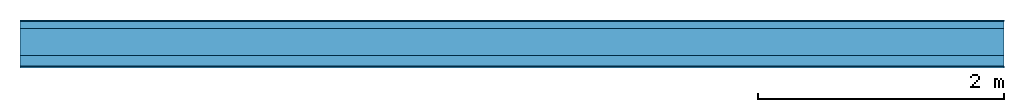
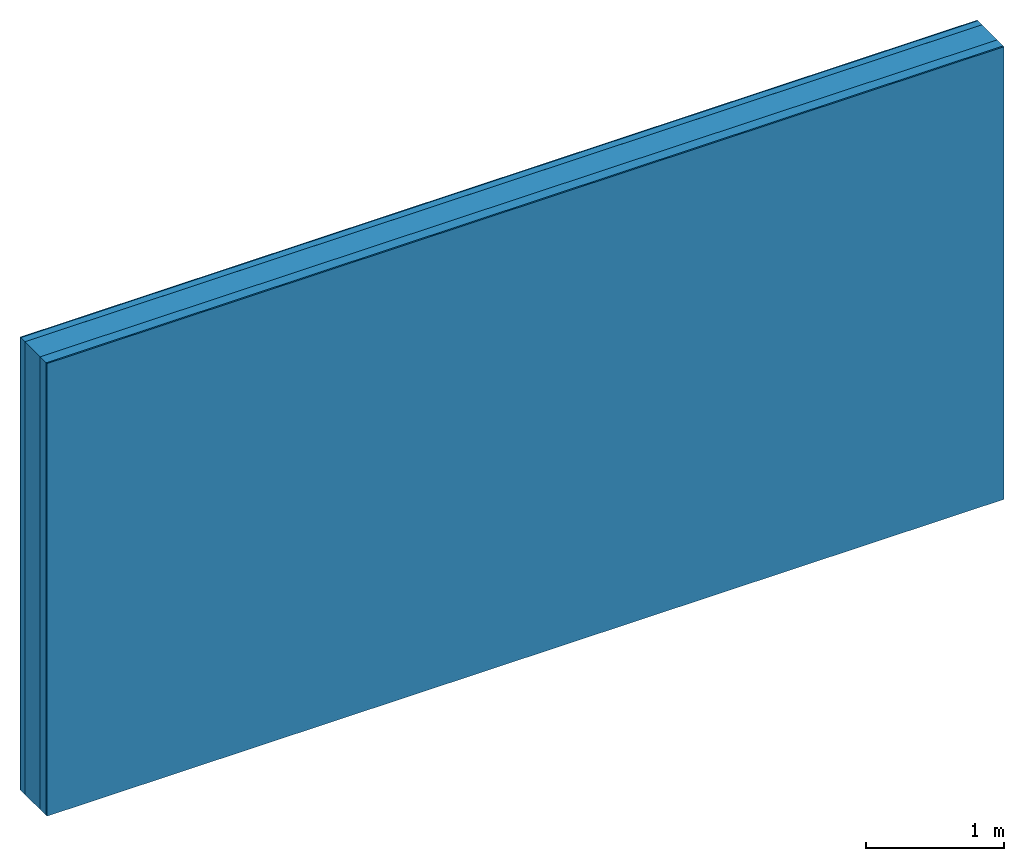
# One storey: 4 plates, 1 member, 1 element without a shape of its own.
"""IFC4 building model written with IfcOpenShell, lengths in metres."""

import ifcopenshell
import ifcopenshell.guid

model = None  # the IFC model being written
_history = None  # IfcOwnerHistory: only IFC2X3 demands one
_inside = {}  # id of a spatial element -> (the spatial element, [elements in it])
_under = {}  # id of a project, library or spatial element -> (it, [spatial elements below it])
_declared = {}  # id of a project -> (the project, [libraries it declares])
_typed = {}  # id of a type object -> (the type object, [elements of that type])
_made_of = {}  # id of a material, layer set ... -> (it, [elements and type objects made of it])


def new_model(schema):
    """Start an empty IFC model of exactly this schema.

    Asked for "IFC4X3", IfcOpenShell would pick the latest addendum, in which some entities
    have other attributes; the version numbers below select the first issue.
    IFC2X3 requires an IfcOwnerHistory on every rooted entity: one is made here for all.
    """
    global model, _history
    if schema == "IFC4X3":
        model = ifcopenshell.file(schema_version=(4, 3, 0, 0))
    else:
        model = ifcopenshell.file(schema=schema)
    _inside.clear()
    _under.clear()
    _declared.clear()
    _typed.clear()
    _made_of.clear()
    _history = None
    if model.schema == "IFC2X3":
        org = make("IfcOrganization", Name="unknown")
        user = make(
            "IfcPersonAndOrganization",
            ThePerson=make("IfcPerson", FamilyName="unknown"),
            TheOrganization=org,
        )
        app = make(
            "IfcApplication",
            ApplicationDeveloper=org,
            Version="unknown",
            ApplicationFullName="unknown",
            ApplicationIdentifier="unknown",
        )
        _history = make(
            "IfcOwnerHistory",
            OwningUser=user,
            OwningApplication=app,
            ChangeAction="ADDED",
            CreationDate=0,
        )
    return model


def make(cls, **values):
    """One entity of the class cls with the attributes given. An attribute that is None is left unset."""
    return model.create_entity(
        cls, **{name: value for name, value in values.items() if value is not None}
    )


def rooted(cls, **values):
    """An entity with a GlobalId (a new one), such as an element, a storey or a relation."""
    return make(cls, GlobalId=ifcopenshell.guid.new(), OwnerHistory=_history, **values)


def si_unit(unit_type, name, prefix=None):
    """IfcSIUnit, for example si_unit("LENGTHUNIT", "METRE", prefix="MILLI")."""
    return make("IfcSIUnit", UnitType=unit_type, Prefix=prefix, Name=name)


def derived_unit(unit_type, elements):
    """IfcDerivedUnit: a product of units, each with its exponent."""
    return make(
        "IfcDerivedUnit",
        Elements=[
            make("IfcDerivedUnitElement", Unit=unit, Exponent=power)
            for unit, power in elements
        ],
        UnitType=unit_type,
    )


def assignment(units):
    """IfcUnitAssignment: the units of a project."""
    return None if units is None else make("IfcUnitAssignment", Units=units)


def point(xyz):
    """IfcCartesianPoint."""
    return None if xyz is None else make("IfcCartesianPoint", Coordinates=xyz)


def direction(xyz):
    """IfcDirection."""
    return None if xyz is None else make("IfcDirection", DirectionRatios=xyz)


def frame(location, z_axis=None, x_axis=None):
    """IfcAxis2Placement3D, a coordinate frame: its origin and axes. An axis left out is left unset."""
    return make(
        "IfcAxis2Placement3D",
        Location=point(location),
        Axis=direction(z_axis),
        RefDirection=direction(x_axis),
    )


def frame_2d(location, x_axis=None):
    """IfcAxis2Placement2D, a coordinate frame in the plane: its origin and x axis."""
    return make(
        "IfcAxis2Placement2D", Location=point(location), RefDirection=direction(x_axis)
    )


def origin():
    """The frame at (0, 0, 0) with its axes left unset."""
    return frame((0.0, 0.0, 0.0))


def origin_with_axes():
    """The frame at (0, 0, 0) with the z axis (0, 0, 1) and the x axis (1, 0, 0) written out."""
    return frame((0.0, 0.0, 0.0), z_axis=(0.0, 0.0, 1.0), x_axis=(1.0, 0.0, 0.0))


def place(relative_to, where):
    """IfcLocalPlacement: puts the frame where relative to a parent placement (None: the world)."""
    return make(
        "IfcLocalPlacement", PlacementRelTo=relative_to, RelativePlacement=where
    )


def context(
    kind, dimensions, precision=None, world=None, true_north=None, identifier=None
):
    """IfcGeometricRepresentationContext, for example the 3D "Model" context."""
    return make(
        "IfcGeometricRepresentationContext",
        ContextIdentifier=identifier,
        ContextType=kind,
        CoordinateSpaceDimension=dimensions,
        Precision=precision,
        WorldCoordinateSystem=world,
        TrueNorth=true_north,
    )


def project(units=None, contexts=None):
    """IfcProject with its units and contexts."""
    return rooted(
        "IfcProject",
        Name="project",
        RepresentationContexts=contexts,
        UnitsInContext=assignment(units),
    )


def spatial(cls, under=None, at=None, **own):
    """A site, building, storey or space (cls), placed at a placement, below another one or the project."""
    s = rooted(cls, ObjectPlacement=at, **own)
    if under is not None:
        _under.setdefault(under.id(), (under, []))[1].append(s)
    return s


def profile(cls, at=None, kind="AREA", **sizes):
    """A parametric profile (cls). Its sizes go by their IFC names, for example OverallWidth=200.0."""
    return make(cls, ProfileType=kind, Position=at, **sizes)


def rectangle(**sizes):
    """IfcRectangleProfileDef."""
    return profile("IfcRectangleProfileDef", **sizes)


def extrude(swept, where, along, depth):
    """IfcExtrudedAreaSolid: the profile swept, set in the frame where, extruded along a direction by depth."""
    return make(
        "IfcExtrudedAreaSolid",
        SweptArea=swept,
        Position=where,
        ExtrudedDirection=direction(along),
        Depth=depth,
    )


def shape(context_of_items, identifier, shape_type, items):
    """IfcShapeRepresentation: the items that make up one representation, for example the "Body"."""
    return make(
        "IfcShapeRepresentation",
        ContextOfItems=context_of_items,
        RepresentationIdentifier=identifier,
        RepresentationType=shape_type,
        Items=items,
    )


def material(Name=None, Category=None):
    """IfcMaterial."""
    return make("IfcMaterial", Name=Name, Category=Category)


def layer(
    of_material, thickness, ventilated=None, Name=None, Category=None, Priority=None
):
    """IfcMaterialLayer: one layer of a wall or slab, of a material (None: an air gap)."""
    return make(
        "IfcMaterialLayer",
        Material=of_material,
        LayerThickness=thickness,
        IsVentilated=ventilated,
        Name=Name,
        Category=Category,
        Priority=Priority,
    )


def layer_set(layers, Name=None):
    """IfcMaterialLayerSet."""
    return make("IfcMaterialLayerSet", MaterialLayers=layers, LayerSetName=Name)


def made_of(thing, what):
    """Note that an element or type object is made of a material, layer set ...; save() writes the relation."""
    if what is not None:
        _made_of.setdefault(what.id(), (what, []))[1].append(thing)
    return thing


def type_object(cls, material=None, **own):
    """A type object (cls), such as IfcWallType, which elements share."""
    return made_of(rooted(cls, **own), material)


def element(
    cls,
    number,
    at=None,
    inside=None,
    cuts=None,
    type_object=None,
    material=None,
    context=None,
    identifier="Body",
    shape_type=None,
    held_by="IfcProductDefinitionShape",
    body=None,
    shapes=None,
    **own,
):
    """One element of the class cls, such as IfcWall. Its Tag is "e" and its number.

    at: its placement. inside: the storey or other place that contains it. cuts: it is an
    opening in that element (IfcRelVoidsElement). A single representation is given by context,
    identifier, shape_type and body (its items); several are given by shapes. held_by: the class
    of the entity that holds the representations. save() writes the other relations.
    """
    e = rooted(cls, Tag="e%d" % number, ObjectPlacement=at, **own)
    if body is not None:
        shapes = [shape(context, identifier, shape_type, body)]
    if shapes is not None:
        e.Representation = make(held_by, Representations=shapes)
    if inside is not None:
        _inside.setdefault(inside.id(), (inside, []))[1].append(e)
    if cuts is not None:
        rooted(
            "IfcRelVoidsElement", RelatingBuildingElement=cuts, RelatedOpeningElement=e
        )
    if type_object is not None:
        _typed.setdefault(type_object.id(), (type_object, []))[1].append(e)
    return made_of(e, material)


def aggregate(whole, parts):
    """IfcRelAggregates: a whole, such as a stair, and the parts it consists of."""
    return rooted("IfcRelAggregates", RelatingObject=whole, RelatedObjects=parts)


def save(model, path):
    """Write the relations noted so far, then the file.

    IfcRelAggregates (storeys below a building ...), IfcRelContainedInSpatialStructure (elements
    in a storey), IfcRelDefinesByType, IfcRelAssociatesMaterial and IfcRelDeclares: one each for
    every whole, place, type object, material and project.
    """
    for whole, parts in _under.values():
        aggregate(whole, parts)
    for where, things in _inside.values():
        rooted(
            "IfcRelContainedInSpatialStructure",
            RelatedElements=things,
            RelatingStructure=where,
        )
    for kind, things in _typed.values():
        rooted("IfcRelDefinesByType", RelatedObjects=things, RelatingType=kind)
    for what, things in _made_of.values():
        rooted("IfcRelAssociatesMaterial", RelatedObjects=things, RelatingMaterial=what)
    for by, libraries in _declared.values():
        rooted("IfcRelDeclares", RelatingContext=by, RelatedDefinitions=libraries)
    model.write(path)


model = new_model("IFC4")

# Units and contexts
plan_context = context("Plan", 3, precision=1e-05, world=origin(), true_north=direction((0.0, 1.0)))
model_context = context("Model", 3, precision=1e-05, world=origin(), true_north=direction((0.0, 1.0)))
ifc_project = project(units=[si_unit("LENGTHUNIT", "METRE"), derived_unit("SOUNDPRESSUREUNIT", [(si_unit("PRESSUREUNIT", "PASCAL", prefix="MICRO"), 0)]), si_unit("ENERGYUNIT", "JOULE", prefix="MEGA"), si_unit("MASSUNIT", "GRAM", prefix="KILO"), derived_unit("THERMALTRANSMITTANCEUNIT", [(si_unit("POWERUNIT", "WATT"), 1), (si_unit("AREAUNIT", "SQUARE_METRE"), -1), (si_unit("THERMODYNAMICTEMPERATUREUNIT", "KELVIN"), -1)]), derived_unit("AREADENSITYUNIT", [(si_unit("MASSUNIT", "GRAM", prefix="KILO"), 1), (si_unit("AREAUNIT", "SQUARE_METRE"), -1)]), derived_unit("USERDEFINED", [(si_unit("ENERGYUNIT", "JOULE", prefix="MEGA"), 1), (si_unit("AREAUNIT", "SQUARE_METRE"), -1)])], contexts=[plan_context, model_context])

# Site, building, storey
site = spatial("IfcSite", under=ifc_project)
building_placement = place(None, origin())
building = spatial("IfcBuilding", under=site, at=building_placement)
storey_placement = place(building_placement, origin())
storey = spatial("IfcBuildingStorey", under=building, at=storey_placement)

# Wall, member, plates
ifc_material_1 = material(Category="04.011")
ifc_layer_1 = layer(ifc_material_1, 0.01, Name="Surface 1")
ifc_material_2 = material(Category="10.009")
ifc_layer_2 = layer(ifc_material_2, 0.06, Name="outside 2nd layer")
ifc_material_3 = material(Category="10.009")
ifc_layer_3 = layer(ifc_material_3, 0.22, Name="outside 1st layer")
ifc_material_4 = material(Name="of the art")
ifc_layer_4 = layer(ifc_material_4, 0.0, Name="Bond")
ifc_layer_5 = layer(None, 0.087, Name="Support")
ifc_layer_6 = layer(ifc_material_4, 0.0, Name="Bond")
ifc_material_5 = material(Name="Plasterboard type A", Category="03.008")
ifc_layer_7 = layer(ifc_material_5, 0.0125, Name="1st layer")
ifc_material_6 = material(Name="joints", Category="04.017")
ifc_layer_8 = layer(ifc_material_6, 0.0, Name="Surface")
ifc_layer_set = layer_set([ifc_layer_1, ifc_layer_2, ifc_layer_3, ifc_layer_4, ifc_layer_5, ifc_layer_6, ifc_layer_7, ifc_layer_8])
wall_type = type_object("IfcWallType", Name="D1032", PredefinedType="NOTDEFINED", material=ifc_layer_set)
wall_placement = place(None, frame((0.0, 0.0, 0.0), z_axis=(0.0, -1.0, 0.0), x_axis=(1.0, 0.0, 0.0)))
wall = element("IfcWall", 1, at=wall_placement, inside=storey, type_object=wall_type, material=ifc_layer_set, Name="Wall #1")
ifc_material_7 = material(Name="Solid timber panel")
member_placement = place(wall_placement, origin())
member = element("IfcMember", 2, at=member_placement, material=ifc_material_7, Name="Support", context=plan_context, shape_type="SweptSolid", body=[
    extrude(rectangle(XDim=1.0, YDim=0.087, at=frame_2d((0.5, 0.0435), x_axis=(1.0, 0.0))), frame((0.0, 4.0, 0.29), z_axis=(0.0, -1.0, 0.0), x_axis=(1.0, 0.0, 0.0)), (0.0, 0.0, 1.0), 4.0),
    extrude(rectangle(XDim=1.0, YDim=0.087, at=frame_2d((0.5, 0.0435), x_axis=(1.0, 0.0))), frame((1.0, 4.0, 0.29), z_axis=(0.0, -1.0, 0.0), x_axis=(1.0, 0.0, 0.0)), (0.0, 0.0, 1.0), 4.0),
    extrude(rectangle(XDim=1.0, YDim=0.087, at=frame_2d((0.5, 0.0435), x_axis=(1.0, 0.0))), frame((2.0, 4.0, 0.29), z_axis=(0.0, -1.0, 0.0), x_axis=(1.0, 0.0, 0.0)), (0.0, 0.0, 1.0), 4.0),
    extrude(rectangle(XDim=1.0, YDim=0.087, at=frame_2d((0.5, 0.0435), x_axis=(1.0, 0.0))), frame((3.0, 4.0, 0.29), z_axis=(0.0, -1.0, 0.0), x_axis=(1.0, 0.0, 0.0)), (0.0, 0.0, 1.0), 4.0),
    extrude(rectangle(XDim=1.0, YDim=0.087, at=frame_2d((0.5, 0.0435), x_axis=(1.0, 0.0))), frame((4.0, 4.0, 0.29), z_axis=(0.0, -1.0, 0.0), x_axis=(1.0, 0.0, 0.0)), (0.0, 0.0, 1.0), 4.0),
    extrude(rectangle(XDim=1.0, YDim=0.087, at=frame_2d((0.5, 0.0435), x_axis=(1.0, 0.0))), frame((5.0, 4.0, 0.29), z_axis=(0.0, -1.0, 0.0), x_axis=(1.0, 0.0, 0.0)), (0.0, 0.0, 1.0), 4.0),
    extrude(rectangle(XDim=1.0, YDim=0.087, at=frame_2d((0.5, 0.0435), x_axis=(1.0, 0.0))), frame((6.0, 4.0, 0.29), z_axis=(0.0, -1.0, 0.0), x_axis=(1.0, 0.0, 0.0)), (0.0, 0.0, 1.0), 4.0),
    extrude(rectangle(XDim=1.0, YDim=0.087, at=frame_2d((0.5, 0.0435), x_axis=(1.0, 0.0))), frame((7.0, 4.0, 0.29), z_axis=(0.0, -1.0, 0.0), x_axis=(1.0, 0.0, 0.0)), (0.0, 0.0, 1.0), 4.0),
])
plate_1_placement = place(wall_placement, origin())
plate_1 = element("IfcPlate", 3, at=plate_1_placement, material=ifc_material_1, Name="Surface 1", context=plan_context, shape_type="SweptSolid", body=[
    extrude(rectangle(XDim=8.0, YDim=4.0, at=frame_2d((4.0, 2.0), x_axis=(1.0, 0.0))), origin_with_axes(), (0.0, 0.0, 1.0), 0.01),
])
plate_2_placement = place(wall_placement, origin())
plate_2 = element("IfcPlate", 4, at=plate_2_placement, material=ifc_material_2, Name="outside 2nd layer", context=plan_context, shape_type="SweptSolid", body=[
    extrude(rectangle(XDim=8.0, YDim=4.0, at=frame_2d((4.0, 2.0), x_axis=(1.0, 0.0))), frame((0.0, 0.0, 0.01), z_axis=(0.0, 0.0, 1.0), x_axis=(1.0, 0.0, 0.0)), (0.0, 0.0, 1.0), 0.06),
])
plate_3_placement = place(wall_placement, origin())
plate_3 = element("IfcPlate", 5, at=plate_3_placement, material=ifc_material_3, Name="outside 1st layer", context=plan_context, shape_type="SweptSolid", body=[
    extrude(rectangle(XDim=8.0, YDim=4.0, at=frame_2d((4.0, 2.0), x_axis=(1.0, 0.0))), frame((0.0, 0.0, 0.07), z_axis=(0.0, 0.0, 1.0), x_axis=(1.0, 0.0, 0.0)), (0.0, 0.0, 1.0), 0.22),
])
plate_4_placement = place(wall_placement, origin())
plate_4 = element("IfcPlate", 6, at=plate_4_placement, material=ifc_material_5, Name="1st layer", context=plan_context, shape_type="SweptSolid", body=[
    extrude(rectangle(XDim=8.0, YDim=4.0, at=frame_2d((4.0, 2.0), x_axis=(1.0, 0.0))), frame((0.0, 0.0, 0.377), z_axis=(0.0, 0.0, 1.0), x_axis=(1.0, 0.0, 0.0)), (0.0, 0.0, 1.0), 0.0125),
])
aggregate(wall, [plate_1, plate_2, plate_3, member, plate_4])

save(model, "model.ifc")
